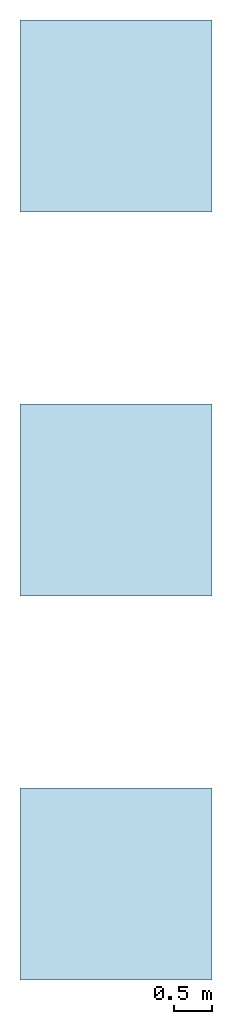
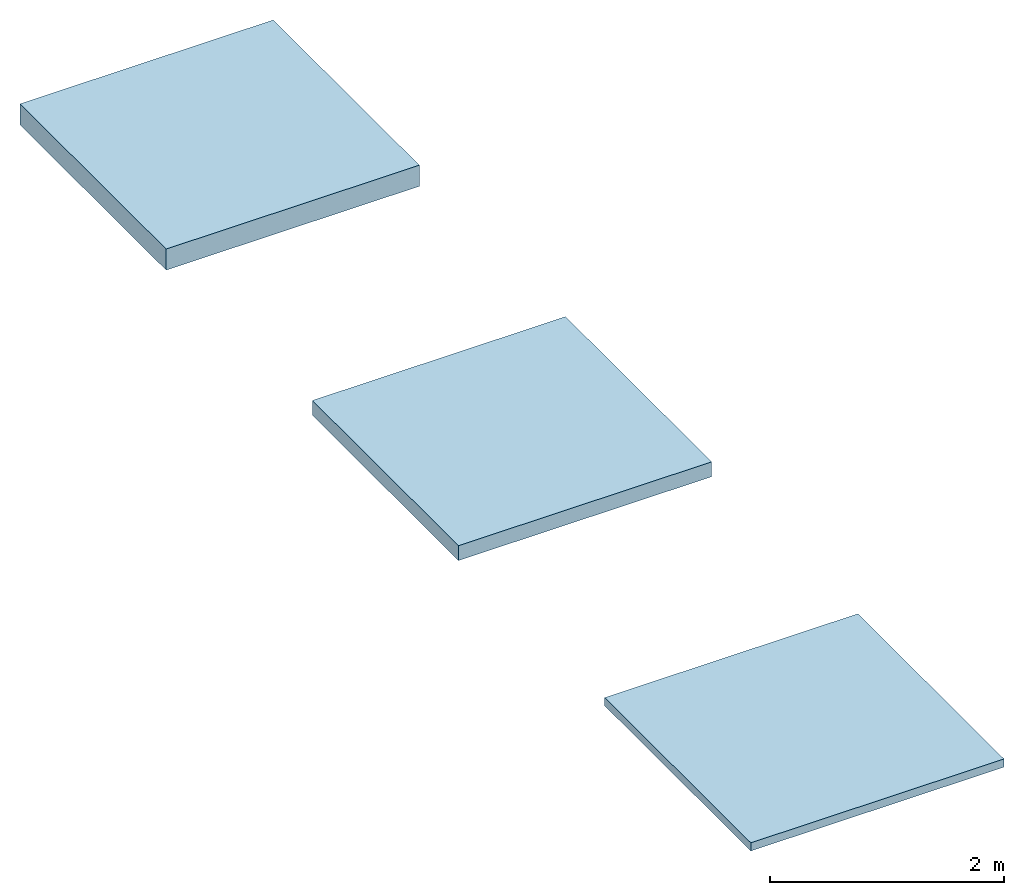
# Not in any storey: 3 slabs.
"""IFC2X3 building model written with IfcOpenShell, lengths in millimetres."""

from ifc_helpers import new_model, si_unit, frame, frame_2d, origin, origin_with_axes, origin_2d, place, context, project, spatial, rectangle, extrude, material, layer, layer_set, layer_usage, type_object, element, save


model = new_model("IFC2X3")

# Units and contexts
model_context = context("Model", 3, precision=1e-05, world=origin())
plan_context = context("Plan", 2, precision=1e-05, world=origin_2d())
ifc_project = project(units=[si_unit("LENGTHUNIT", "METRE", prefix="MILLI"), si_unit("AREAUNIT", "SQUARE_METRE"), si_unit("VOLUMEUNIT", "CUBIC_METRE"), si_unit("SOLIDANGLEUNIT", "STERADIAN"), si_unit("PLANEANGLEUNIT", "RADIAN"), si_unit("MASSUNIT", "GRAM"), si_unit("TIMEUNIT", "SECOND"), si_unit("THERMODYNAMICTEMPERATUREUNIT", "DEGREE_CELSIUS"), si_unit("LUMINOUSINTENSITYUNIT", "LUMEN")], contexts=[model_context, plan_context])

# Site, building
site_placement = place(None, frame((0.0, 0.0, 0.0), z_axis=(0.0, 1.0, 0.0), x_axis=(0.0, 0.0, 1.0)))
site = spatial("IfcSite", under=ifc_project, at=site_placement, CompositionType="ELEMENT")
building_placement = place(site_placement, frame((0.0, 0.0, 0.0), z_axis=(0.0, 1.0, 0.0), x_axis=(0.0, 0.0, 1.0)))
building = spatial("IfcBuilding", under=site, at=building_placement, Name="Default building", CompositionType="ELEMENT")

# Slabs
ifc_material_1 = material()
ifc_layer_1 = layer(ifc_material_1, 85.0, ventilated=False)
ifc_layer_set_1 = layer_set([ifc_layer_1])
ifc_layer_usage_1 = layer_usage(ifc_layer_set_1, "AXIS3", "NEGATIVE", 0.0)
slab_type_1 = type_object("IfcSlabType", PredefinedType="FLOOR", material=ifc_layer_set_1)
slab_1_placement = place(None, origin())
element("IfcSlab", 1, at=slab_1_placement, inside=building, type_object=slab_type_1, material=ifc_layer_usage_1, PredefinedType="FLOOR", context=model_context, shape_type="SweptSolid", body=[
    extrude(rectangle(XDim=2500.0, YDim=2500.0, at=frame_2d((1250.0, 1250.0))), origin_with_axes(), (0.0, 0.0, 1.0), 85.0),
])
ifc_material_2 = material()
ifc_layer_2 = layer(ifc_material_2, 155.0, ventilated=False)
ifc_layer_set_2 = layer_set([ifc_layer_2])
ifc_layer_usage_2 = layer_usage(ifc_layer_set_2, "AXIS3", "NEGATIVE", 0.0)
slab_type_2 = type_object("IfcSlabType", PredefinedType="FLOOR", material=ifc_layer_set_2)
slab_2_placement = place(None, frame((0.0, 5000.0, 0.0)))
element("IfcSlab", 2, at=slab_2_placement, inside=building, type_object=slab_type_2, material=ifc_layer_usage_2, PredefinedType="FLOOR", context=model_context, shape_type="SweptSolid", body=[
    extrude(rectangle(XDim=2500.0, YDim=2500.0, at=frame_2d((1250.0, 1250.0))), origin_with_axes(), (0.0, 0.0, 1.0), 155.0),
])
ifc_material_3 = material()
ifc_layer_3 = layer(ifc_material_3, 220.0, ventilated=False)
ifc_layer_set_3 = layer_set([ifc_layer_3])
ifc_layer_usage_3 = layer_usage(ifc_layer_set_3, "AXIS3", "NEGATIVE", 0.0)
slab_type_3 = type_object("IfcSlabType", PredefinedType="FLOOR", material=ifc_layer_set_3)
slab_3_placement = place(None, frame((0.0, 10000.0, 0.0)))
element("IfcSlab", 3, at=slab_3_placement, inside=building, type_object=slab_type_3, material=ifc_layer_usage_3, PredefinedType="FLOOR", context=model_context, shape_type="SweptSolid", body=[
    extrude(rectangle(XDim=2500.0, YDim=2500.0, at=frame_2d((1250.0, 1250.0))), origin_with_axes(), (0.0, 0.0, 1.0), 220.0),
])

save(model, "model.ifc")
